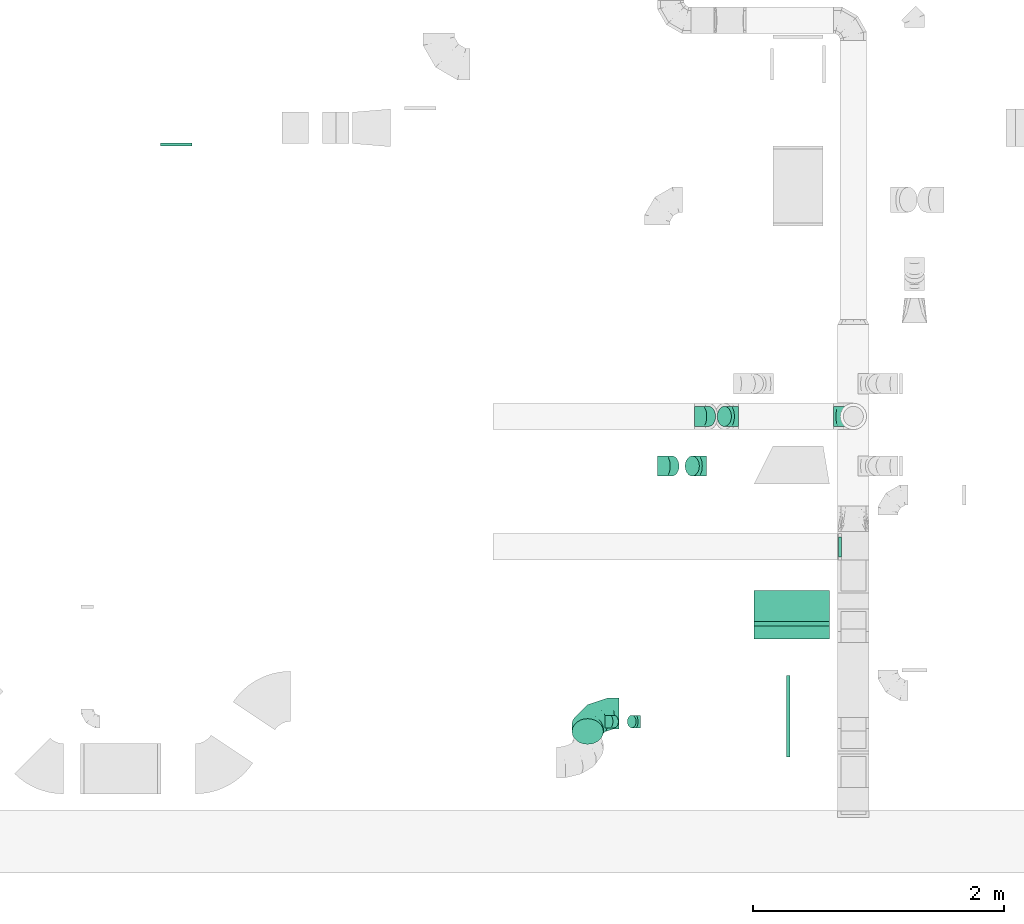
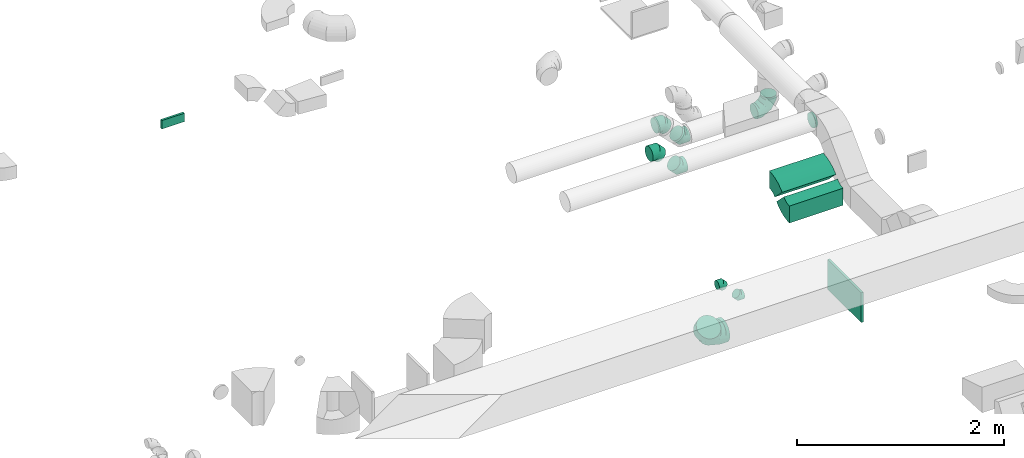
# One storey, part 34 of 62: 13 flow fittings.
"""IFC2X3 building model written with IfcOpenShell, lengths in millimetres."""

import ifcopenshell
import ifcopenshell.guid

model = None  # the IFC model being written
_history = None  # IfcOwnerHistory: only IFC2X3 demands one
_inside = {}  # id of a spatial element -> (the spatial element, [elements in it])
_under = {}  # id of a project, library or spatial element -> (it, [spatial elements below it])
_declared = {}  # id of a project -> (the project, [libraries it declares])
_typed = {}  # id of a type object -> (the type object, [elements of that type])
_made_of = {}  # id of a material, layer set ... -> (it, [elements and type objects made of it])


def new_model(schema):
    """Start an empty IFC model of exactly this schema.

    Asked for "IFC4X3", IfcOpenShell would pick the latest addendum, in which some entities
    have other attributes; the version numbers below select the first issue.
    IFC2X3 requires an IfcOwnerHistory on every rooted entity: one is made here for all.
    """
    global model, _history
    if schema == "IFC4X3":
        model = ifcopenshell.file(schema_version=(4, 3, 0, 0))
    else:
        model = ifcopenshell.file(schema=schema)
    _inside.clear()
    _under.clear()
    _declared.clear()
    _typed.clear()
    _made_of.clear()
    _history = None
    if model.schema == "IFC2X3":
        org = make("IfcOrganization", Name="unknown")
        user = make(
            "IfcPersonAndOrganization",
            ThePerson=make("IfcPerson", FamilyName="unknown"),
            TheOrganization=org,
        )
        app = make(
            "IfcApplication",
            ApplicationDeveloper=org,
            Version="unknown",
            ApplicationFullName="unknown",
            ApplicationIdentifier="unknown",
        )
        _history = make(
            "IfcOwnerHistory",
            OwningUser=user,
            OwningApplication=app,
            ChangeAction="ADDED",
            CreationDate=0,
        )
    return model


def make(cls, **values):
    """One entity of the class cls with the attributes given. An attribute that is None is left unset."""
    return model.create_entity(
        cls, **{name: value for name, value in values.items() if value is not None}
    )


def entity(cls, *values):
    """Any entity or typed value of the class cls, its attributes in the order of the schema. None: left unset."""
    e = model.create_entity(cls)
    for i, value in enumerate(values):
        if value is not None:
            e[i] = value
    return e


def rooted(cls, **values):
    """An entity with a GlobalId (a new one), such as an element, a storey or a relation."""
    return make(cls, GlobalId=ifcopenshell.guid.new(), OwnerHistory=_history, **values)


def si_unit(unit_type, name, prefix=None):
    """IfcSIUnit, for example si_unit("LENGTHUNIT", "METRE", prefix="MILLI")."""
    return make("IfcSIUnit", UnitType=unit_type, Prefix=prefix, Name=name)


def converted_unit(unit_type, name, factor, base, dimensions=None, offset=None):
    """IfcConversionBasedUnit, such as the inch: factor (a typed value) times the base unit."""
    return make(
        "IfcConversionBasedUnit"
        if offset is None
        else "IfcConversionBasedUnitWithOffset",
        ConversionOffset=offset,
        Dimensions=None
        if dimensions is None
        else entity("IfcDimensionalExponents", *dimensions),
        UnitType=unit_type,
        Name=name,
        ConversionFactor=make(
            "IfcMeasureWithUnit", ValueComponent=factor, UnitComponent=base
        ),
    )


def derived_unit(unit_type, elements):
    """IfcDerivedUnit: a product of units, each with its exponent."""
    return make(
        "IfcDerivedUnit",
        Elements=[
            make("IfcDerivedUnitElement", Unit=unit, Exponent=power)
            for unit, power in elements
        ],
        UnitType=unit_type,
    )


def assignment(units):
    """IfcUnitAssignment: the units of a project."""
    return None if units is None else make("IfcUnitAssignment", Units=units)


def point(xyz):
    """IfcCartesianPoint."""
    return None if xyz is None else make("IfcCartesianPoint", Coordinates=xyz)


def direction(xyz):
    """IfcDirection."""
    return None if xyz is None else make("IfcDirection", DirectionRatios=xyz)


def frame(location, z_axis=None, x_axis=None):
    """IfcAxis2Placement3D, a coordinate frame: its origin and axes. An axis left out is left unset."""
    return make(
        "IfcAxis2Placement3D",
        Location=point(location),
        Axis=direction(z_axis),
        RefDirection=direction(x_axis),
    )


def frame_2d(location, x_axis=None):
    """IfcAxis2Placement2D, a coordinate frame in the plane: its origin and x axis."""
    return make(
        "IfcAxis2Placement2D", Location=point(location), RefDirection=direction(x_axis)
    )


def origin():
    """The frame at (0, 0, 0) with its axes left unset."""
    return frame((0.0, 0.0, 0.0))


def origin_2d_with_axis():
    """The frame at (0, 0) in the plane with the x axis (1, 0) written out."""
    return frame_2d((0.0, 0.0), x_axis=(1.0, 0.0))


def place(relative_to, where):
    """IfcLocalPlacement: puts the frame where relative to a parent placement (None: the world)."""
    return make(
        "IfcLocalPlacement", PlacementRelTo=relative_to, RelativePlacement=where
    )


def context(
    kind, dimensions, precision=None, world=None, true_north=None, identifier=None
):
    """IfcGeometricRepresentationContext, for example the 3D "Model" context."""
    return make(
        "IfcGeometricRepresentationContext",
        ContextIdentifier=identifier,
        ContextType=kind,
        CoordinateSpaceDimension=dimensions,
        Precision=precision,
        WorldCoordinateSystem=world,
        TrueNorth=true_north,
    )


def subcontext(parent, identifier, kind, view, scale=None):
    """IfcGeometricRepresentationSubContext, for example "Body" below "Model"."""
    return make(
        "IfcGeometricRepresentationSubContext",
        ContextIdentifier=identifier,
        ContextType=kind,
        ParentContext=parent,
        TargetScale=scale,
        TargetView=view,
    )


def project(units=None, contexts=None):
    """IfcProject with its units and contexts."""
    return rooted(
        "IfcProject",
        Name="project",
        RepresentationContexts=contexts,
        UnitsInContext=assignment(units),
    )


def spatial(cls, under=None, at=None, **own):
    """A site, building, storey or space (cls), placed at a placement, below another one or the project."""
    s = rooted(cls, ObjectPlacement=at, **own)
    if under is not None:
        _under.setdefault(under.id(), (under, []))[1].append(s)
    return s


def polyline(points):
    """IfcPolyline through the points."""
    return make("IfcPolyline", Points=[point(p) for p in points])


def circle_curve(where, radius):
    """IfcCircle in the frame where."""
    return make("IfcCircle", Position=where, Radius=radius)


def parameter(value):
    """IfcParameterValue: where a trimmed curve begins or ends, as a parameter of its basis curve."""
    return model.create_entity("IfcParameterValue", value)


def trimmed(basis, trim1, trim2, sense, master):
    """IfcTrimmedCurve: the piece of a basis curve between two trims."""
    return make(
        "IfcTrimmedCurve",
        BasisCurve=basis,
        Trim1=trim1,
        Trim2=trim2,
        SenseAgreement=sense,
        MasterRepresentation=master,
    )


def segment(curve, same_sense, transition):
    """IfcCompositeCurveSegment."""
    return make(
        "IfcCompositeCurveSegment",
        Transition=transition,
        SameSense=same_sense,
        ParentCurve=curve,
    )


def composite_curve(segments, self_intersect=None):
    """IfcCompositeCurve: segments joined end to end."""
    return make("IfcCompositeCurve", Segments=segments, SelfIntersect=self_intersect)


def profile(cls, at=None, kind="AREA", **sizes):
    """A parametric profile (cls). Its sizes go by their IFC names, for example OverallWidth=200.0."""
    return make(cls, ProfileType=kind, Position=at, **sizes)


def rectangle(**sizes):
    """IfcRectangleProfileDef."""
    return profile("IfcRectangleProfileDef", **sizes)


def outline(outer, holes=None, kind="AREA"):
    """IfcArbitraryClosedProfileDef: a profile drawn as a closed curve; with holes, ...WithVoids."""
    if holes is None:
        return make("IfcArbitraryClosedProfileDef", ProfileType=kind, OuterCurve=outer)
    return make(
        "IfcArbitraryProfileDefWithVoids",
        ProfileType=kind,
        OuterCurve=outer,
        InnerCurves=holes,
    )


def extrude(swept, where, along, depth):
    """IfcExtrudedAreaSolid: the profile swept, set in the frame where, extruded along a direction by depth."""
    return make(
        "IfcExtrudedAreaSolid",
        SweptArea=swept,
        Position=where,
        ExtrudedDirection=direction(along),
        Depth=depth,
    )


def faces_of(points, faces, orient=None, outer=None):
    """IfcFace entities. A face is a list of loops; a loop is a list of indices into points, from 0.

    orient and outer hold one flag for each loop. By default every Orientation is true, the
    first loop of a face is its IfcFaceOuterBound and the others are IfcFaceBound.
    """
    made = []
    for i, loops in enumerate(faces):
        bounds = []
        for j, loop in enumerate(loops):
            is_outer = j == 0 if outer is None else outer[i][j]
            bounds.append(
                make(
                    "IfcFaceOuterBound" if is_outer else "IfcFaceBound",
                    Bound=make("IfcPolyLoop", Polygon=[points[k] for k in loop]),
                    Orientation=True if orient is None else orient[i][j],
                )
            )
        made.append(make("IfcFace", Bounds=bounds))
    return made


def faceted_brep(points, faces, orient=None, outer=None, voids=None):
    """IfcFacetedBrep: a solid bounded by flat faces; with voids (closed shells), ...WithVoids."""
    shared = [point(p) for p in points]
    hull = make("IfcClosedShell", CfsFaces=faces_of(shared, faces, orient, outer))
    if voids is None:
        return make("IfcFacetedBrep", Outer=hull)
    return make(
        "IfcFacetedBrepWithVoids",
        Outer=hull,
        Voids=[
            make(cls, CfsFaces=faces_of(shared, fs, o, b)) for cls, fs, o, b in voids
        ],
    )


def shape(context_of_items, identifier, shape_type, items):
    """IfcShapeRepresentation: the items that make up one representation, for example the "Body"."""
    return make(
        "IfcShapeRepresentation",
        ContextOfItems=context_of_items,
        RepresentationIdentifier=identifier,
        RepresentationType=shape_type,
        Items=items,
    )


def source(mapping_origin, context_of_items, identifier, shape_type, items):
    """IfcRepresentationMap: a shape defined once, which mapped items show again and again."""
    return make(
        "IfcRepresentationMap",
        MappingOrigin=mapping_origin,
        MappedRepresentation=shape(context_of_items, identifier, shape_type, items),
    )


def transform(
    local_origin,
    x_axis=None,
    y_axis=None,
    z_axis=None,
    scale=None,
    scale2=None,
    scale3=None,
    uniform=True,
):
    """IfcCartesianTransformationOperator3D, or its non-uniform kind. x_axis, y_axis, z_axis: its Axis1, 2, 3."""
    if uniform:
        return make(
            "IfcCartesianTransformationOperator3D",
            Axis1=direction(x_axis),
            Axis2=direction(y_axis),
            LocalOrigin=point(local_origin),
            Scale=scale,
            Axis3=direction(z_axis),
        )
    return make(
        "IfcCartesianTransformationOperator3DnonUniform",
        Axis1=direction(x_axis),
        Axis2=direction(y_axis),
        LocalOrigin=point(local_origin),
        Scale=scale,
        Axis3=direction(z_axis),
        Scale2=scale2,
        Scale3=scale3,
    )


def mapped(mapping_source, mapping_target):
    """IfcMappedItem: shows the shape of a source again, moved by a transform."""
    return make(
        "IfcMappedItem", MappingSource=mapping_source, MappingTarget=mapping_target
    )


def material(Name=None, Category=None):
    """IfcMaterial."""
    return make("IfcMaterial", Name=Name, Category=Category)


def made_of(thing, what):
    """Note that an element or type object is made of a material, layer set ...; save() writes the relation."""
    if what is not None:
        _made_of.setdefault(what.id(), (what, []))[1].append(thing)
    return thing


def type_object(cls, material=None, **own):
    """A type object (cls), such as IfcWallType, which elements share."""
    return made_of(rooted(cls, **own), material)


def type_shapes(of_type, sources):
    """Give a type object the sources (RepresentationMaps) that its elements show as mapped items."""
    of_type.RepresentationMaps = sources


def element(
    cls,
    number,
    at=None,
    inside=None,
    cuts=None,
    type_object=None,
    material=None,
    context=None,
    identifier="Body",
    shape_type=None,
    held_by="IfcProductDefinitionShape",
    body=None,
    shapes=None,
    **own,
):
    """One element of the class cls, such as IfcWall. Its Tag is "e" and its number.

    at: its placement. inside: the storey or other place that contains it. cuts: it is an
    opening in that element (IfcRelVoidsElement). A single representation is given by context,
    identifier, shape_type and body (its items); several are given by shapes. held_by: the class
    of the entity that holds the representations. save() writes the other relations.
    """
    e = rooted(cls, Tag="e%d" % number, ObjectPlacement=at, **own)
    if body is not None:
        shapes = [shape(context, identifier, shape_type, body)]
    if shapes is not None:
        e.Representation = make(held_by, Representations=shapes)
    if inside is not None:
        _inside.setdefault(inside.id(), (inside, []))[1].append(e)
    if cuts is not None:
        rooted(
            "IfcRelVoidsElement", RelatingBuildingElement=cuts, RelatedOpeningElement=e
        )
    if type_object is not None:
        _typed.setdefault(type_object.id(), (type_object, []))[1].append(e)
    return made_of(e, material)


def aggregate(whole, parts):
    """IfcRelAggregates: a whole, such as a stair, and the parts it consists of."""
    return rooted("IfcRelAggregates", RelatingObject=whole, RelatedObjects=parts)


def save(model, path):
    """Write the relations noted so far, then the file.

    IfcRelAggregates (storeys below a building ...), IfcRelContainedInSpatialStructure (elements
    in a storey), IfcRelDefinesByType, IfcRelAssociatesMaterial and IfcRelDeclares: one each for
    every whole, place, type object, material and project.
    """
    for whole, parts in _under.values():
        aggregate(whole, parts)
    for where, things in _inside.values():
        rooted(
            "IfcRelContainedInSpatialStructure",
            RelatedElements=things,
            RelatingStructure=where,
        )
    for kind, things in _typed.values():
        rooted("IfcRelDefinesByType", RelatedObjects=things, RelatingType=kind)
    for what, things in _made_of.values():
        rooted("IfcRelAssociatesMaterial", RelatedObjects=things, RelatingMaterial=what)
    for by, libraries in _declared.values():
        rooted("IfcRelDeclares", RelatingContext=by, RelatedDefinitions=libraries)
    model.write(path)


model = new_model("IFC2X3")

# Units and contexts
model_context = context("Model", 3, precision=0.01, world=origin(), true_north=direction((6.12303176911189e-17, 1.0)))
body_context = subcontext(model_context, "Body", "Model", "MODEL_VIEW")
ifc_project = project(units=[si_unit("LENGTHUNIT", "METRE", prefix="MILLI"), si_unit("AREAUNIT", "SQUARE_METRE"), si_unit("VOLUMEUNIT", "CUBIC_METRE"), converted_unit("PLANEANGLEUNIT", "DEGREE", entity("IfcRatioMeasure", 0.0174532925199433), si_unit("PLANEANGLEUNIT", "RADIAN"), dimensions=[0, 0, 0, 0, 0, 0, 0]), si_unit("MASSUNIT", "GRAM", prefix="KILO"), derived_unit("MASSDENSITYUNIT", [(si_unit("MASSUNIT", "GRAM", prefix="KILO"), 1), (si_unit("LENGTHUNIT", "METRE"), -3)]), derived_unit("MOMENTOFINERTIAUNIT", [(si_unit("LENGTHUNIT", "METRE"), 4)]), si_unit("TIMEUNIT", "SECOND"), si_unit("FREQUENCYUNIT", "HERTZ"), si_unit("THERMODYNAMICTEMPERATUREUNIT", "DEGREE_CELSIUS"), derived_unit("THERMALTRANSMITTANCEUNIT", [(si_unit("MASSUNIT", "GRAM", prefix="KILO"), 1), (si_unit("THERMODYNAMICTEMPERATUREUNIT", "KELVIN"), -1), (si_unit("TIMEUNIT", "SECOND"), -3)]), derived_unit("VOLUMETRICFLOWRATEUNIT", [(si_unit("LENGTHUNIT", "METRE"), 3), (si_unit("TIMEUNIT", "SECOND"), -1)]), derived_unit("MASSFLOWRATEUNIT", [(si_unit("MASSUNIT", "GRAM", prefix="KILO"), 1), (si_unit("TIMEUNIT", "SECOND"), -1)]), derived_unit("ROTATIONALFREQUENCYUNIT", [(si_unit("TIMEUNIT", "SECOND"), -1)]), si_unit("ELECTRICCURRENTUNIT", "AMPERE"), si_unit("ELECTRICVOLTAGEUNIT", "VOLT"), si_unit("POWERUNIT", "WATT"), si_unit("FORCEUNIT", "NEWTON", prefix="KILO"), si_unit("ILLUMINANCEUNIT", "LUX"), si_unit("LUMINOUSFLUXUNIT", "LUMEN"), si_unit("LUMINOUSINTENSITYUNIT", "CANDELA"), derived_unit("USERDEFINED", [(si_unit("MASSUNIT", "GRAM", prefix="KILO"), -1), (si_unit("LENGTHUNIT", "METRE"), -2), (si_unit("TIMEUNIT", "SECOND"), 3), (si_unit("LUMINOUSFLUXUNIT", "LUMEN"), 1)]), derived_unit("LINEARVELOCITYUNIT", [(si_unit("LENGTHUNIT", "METRE"), 1), (si_unit("TIMEUNIT", "SECOND"), -1)]), si_unit("PRESSUREUNIT", "PASCAL"), derived_unit("USERDEFINED", [(si_unit("LENGTHUNIT", "METRE"), -2), (si_unit("MASSUNIT", "GRAM", prefix="KILO"), 1), (si_unit("TIMEUNIT", "SECOND"), -2)]), derived_unit("LINEARFORCEUNIT", [(si_unit("MASSUNIT", "GRAM", prefix="KILO"), 1), (si_unit("LENGTHUNIT", "METRE"), 1), (si_unit("TIMEUNIT", "SECOND"), -2), (si_unit("LENGTHUNIT", "METRE"), -1)]), derived_unit("PLANARFORCEUNIT", [(si_unit("MASSUNIT", "GRAM", prefix="KILO"), 1), (si_unit("LENGTHUNIT", "METRE"), 1), (si_unit("TIMEUNIT", "SECOND"), -2), (si_unit("LENGTHUNIT", "METRE"), -2)])], contexts=[model_context])

# Site, building, storey
site_placement = place(None, origin())
site = spatial("IfcSite", under=ifc_project, at=site_placement, CompositionType="ELEMENT")
building_placement = place(site_placement, origin())
building = spatial("IfcBuilding", under=site, at=building_placement, CompositionType="ELEMENT")
storey_placement = place(building_placement, frame((0.0, 0.0, 24000.0)))
storey = spatial("IfcBuildingStorey", under=building, at=storey_placement, CompositionType="ELEMENT", Elevation=24000.0)

# Flow fittings
ifc_material = material()
duct_fitting_type_1 = type_object("IfcDuctFittingType", PredefinedType="NOTDEFINED", material=ifc_material)
shared_shape_1 = source(origin(), body_context, "Body", "SweptSolid", [
    extrude(rectangle(XDim=26.096000000009, YDim=250.0, at=origin_2d_with_axis()), frame((6.95, 0.0, -50.0)), (0.0, 0.0, 1.0), 100.0),
])
type_shapes(duct_fitting_type_1, [shared_shape_1])
flow_fitting_1_placement = place(storey_placement, frame((45368.22, 14481.21, 3550.0), z_axis=(0.0, 0.0, -1.0), x_axis=(0.0, -1.0, 0.0)))
element("IfcFlowFitting", 1, at=flow_fitting_1_placement, inside=storey, type_object=duct_fitting_type_1, material=ifc_material, context=body_context, shape_type="MappedRepresentation", body=[
    mapped(shared_shape_1, transform((0.0, 0.0, 0.0), scale=1.0)),
])
duct_fitting_type_2 = type_object("IfcDuctFittingType", PredefinedType="NOTDEFINED", material=ifc_material)
shared_shape_2 = source(origin(), body_context, "Body", "SweptSolid", [
    extrude(rectangle(XDim=24.9999999999999, YDim=650.0, at=origin_2d_with_axis()), frame((12.5, 0.0, -175.0)), (0.0, 0.0, 1.0), 350.0),
])
type_shapes(duct_fitting_type_2, [shared_shape_2])
flow_fitting_2_placement = place(storey_placement, frame((50225.82, 9925.03, 2600.0)))
element("IfcFlowFitting", 2, at=flow_fitting_2_placement, inside=storey, type_object=duct_fitting_type_2, material=ifc_material, context=body_context, shape_type="MappedRepresentation", body=[
    mapped(shared_shape_2, transform((0.0, 0.0, 0.0), scale=1.0)),
])
duct_fitting_type_3 = type_object("IfcDuctFittingType", PredefinedType="NOTDEFINED", material=ifc_material)
shared_shape_3 = source(origin(), body_context, "Body", "Brep", [
    faceted_brep([(-160.0, 0.0, -80.0), (-160.0, -20.71, -77.27), (-160.0, -40.0, -69.28), (-160.0, -56.57, -56.57), (-160.0, -69.28, -40.0), (-160.0, -77.27, -20.71), (-160.0, -80.0, 0.0), (-160.0, -77.27, 20.71), (-160.0, -69.28, 40.0), (-160.0, -56.57, 56.57), (-160.0, -40.0, 69.28), (-160.0, -20.71, 77.27), (-160.0, 0.0, 80.0), (-160.0, 20.71, 77.27), (-160.0, 40.0, 69.28), (-160.0, 56.57, 56.57), (-160.0, 69.28, 40.0), (-160.0, 77.27, 20.71), (-160.0, 80.0, 0.0), (-160.0, 77.27, -20.71), (-160.0, 69.28, -40.0), (-160.0, 56.57, -56.57), (-160.0, 40.0, -69.28), (-160.0, 20.71, -77.27), (-122.68, 20.71, 77.27), (-127.85, 40.0, 69.28), (-117.13, 0.0, 80.0), (-132.29, 56.57, 56.57), (-137.83, 77.27, 20.71), (-138.56, 80.0, 0.0), (-135.69, 69.28, 40.0), (-135.69, 69.28, -40.0), (-132.29, 56.57, -56.57), (-137.83, 77.27, -20.71), (-122.68, 20.71, -77.27), (-117.13, 0.0, -80.0), (-127.85, 40.0, -69.28), (-111.58, -20.71, -77.27), (-106.41, -40.0, -69.28), (-101.97, -56.57, -56.57), (-98.56, -69.28, -40.0), (-96.42, -77.27, -20.71), (-95.69, -80.0, 0.0), (-96.42, -77.27, 20.71), (-98.56, -69.28, 40.0), (-101.97, -56.57, 56.57), (-106.41, -40.0, 69.28), (-111.58, -20.71, 77.27), (-58.03, 58.03, 77.27), (-72.15, 72.15, 69.28), (-42.87, 42.87, 80.0), (-84.28, 84.28, 56.57), (-93.59, 93.59, 40.0), (-99.44, 99.44, 20.71), (-101.44, 101.44, 0.0), (-99.44, 99.44, -20.71), (-93.59, 93.59, -40.0), (-84.28, 84.28, -56.57), (-58.03, 58.03, -77.27), (-42.87, 42.87, -80.0), (-72.15, 72.15, -69.28), (-27.71, 27.71, -77.27), (-13.59, 13.59, -69.28), (-1.46, 1.46, -56.57), (7.85, -7.85, -40.0), (13.7, -13.7, -20.71), (15.69, -15.69, 0.0), (13.7, -13.7, 20.71), (7.85, -7.85, 40.0), (-1.46, 1.46, 56.57), (-13.59, 13.59, 69.28), (-27.71, 27.71, 77.27), (-20.71, 122.68, 77.27), (-40.0, 127.85, 69.28), (0.0, 117.13, 80.0), (-56.57, 132.29, 56.57), (-69.28, 135.69, 40.0), (-77.27, 137.83, 20.71), (-80.0, 138.56, 0.0), (-77.27, 137.83, -20.71), (-69.28, 135.69, -40.0), (-56.57, 132.29, -56.57), (-20.71, 122.68, -77.27), (0.0, 117.13, -80.0), (-40.0, 127.85, -69.28), (20.71, 111.58, -77.27), (40.0, 106.41, -69.28), (56.57, 101.97, -56.57), (69.28, 98.56, -40.0), (77.27, 96.42, -20.71), (80.0, 95.69, 0.0), (77.27, 96.42, 20.71), (69.28, 98.56, 40.0), (56.57, 101.97, 56.57), (40.0, 106.41, 69.28), (20.71, 111.58, 77.27), (-20.71, 160.0, -77.27), (-40.0, 160.0, -69.28), (-56.57, 160.0, -56.57), (-69.28, 160.0, -40.0), (-77.27, 160.0, -20.71), (-80.0, 160.0, 0.0), (-77.27, 160.0, 20.71), (-69.28, 160.0, 40.0), (-56.57, 160.0, 56.57), (-40.0, 160.0, 69.28), (-20.71, 160.0, 77.27), (0.0, 160.0, 80.0), (20.71, 160.0, 77.27), (40.0, 160.0, 69.28), (56.57, 160.0, 56.57), (69.28, 160.0, 40.0), (77.27, 160.0, 20.71), (80.0, 160.0, 0.0), (77.27, 160.0, -20.71), (69.28, 160.0, -40.0), (56.57, 160.0, -56.57), (40.0, 160.0, -69.28), (20.71, 160.0, -77.27), (0.0, 160.0, -80.0)], [[[0, 1, 2, 3, 4, 5, 6, 7, 8, 9, 10, 11, 12, 13, 14, 15, 16, 17, 18, 19, 20, 21, 22, 23]], [[24, 25, 14, 13]], [[26, 24, 13, 12]], [[14, 25, 27, 15]], [[28, 29, 18, 17]], [[30, 28, 17, 16]], [[15, 27, 30, 16]], [[20, 31, 32, 21]], [[33, 31, 20, 19]], [[18, 29, 33, 19]], [[34, 35, 0, 23]], [[36, 34, 23, 22]], [[32, 36, 22, 21]], [[1, 0, 35, 37]], [[2, 1, 37, 38]], [[3, 2, 38, 39]], [[5, 4, 40, 41]], [[6, 5, 41, 42]], [[39, 40, 4, 3]], [[6, 42, 43, 7]], [[7, 43, 44, 8]], [[8, 44, 45, 9]], [[9, 45, 46, 10]], [[10, 46, 47, 11]], [[26, 12, 11, 47]], [[48, 49, 25, 24]], [[50, 48, 24, 26]], [[27, 25, 49, 51]], [[52, 53, 28, 30]], [[51, 52, 30, 27]], [[29, 28, 53, 54]], [[55, 56, 31, 33]], [[54, 55, 33, 29]], [[32, 31, 56, 57]], [[58, 59, 35, 34]], [[60, 58, 34, 36]], [[57, 60, 36, 32]], [[37, 35, 59, 61]], [[38, 37, 61, 62]], [[39, 38, 62, 63]], [[41, 40, 64, 65]], [[42, 41, 65, 66]], [[63, 64, 40, 39]], [[43, 42, 66, 67]], [[44, 43, 67, 68]], [[68, 69, 45, 44]], [[46, 45, 69, 70]], [[47, 46, 70, 71]], [[26, 47, 71, 50]], [[72, 73, 49, 48]], [[74, 72, 48, 50]], [[51, 49, 73, 75]], [[76, 77, 53, 52]], [[75, 76, 52, 51]], [[54, 53, 77, 78]], [[79, 80, 56, 55]], [[78, 79, 55, 54]], [[57, 56, 80, 81]], [[82, 83, 59, 58]], [[84, 82, 58, 60]], [[81, 84, 60, 57]], [[61, 59, 83, 85]], [[62, 61, 85, 86]], [[63, 62, 86, 87]], [[65, 64, 88, 89]], [[66, 65, 89, 90]], [[87, 88, 64, 63]], [[67, 66, 90, 91]], [[68, 67, 91, 92]], [[92, 93, 69, 68]], [[70, 69, 93, 94]], [[71, 70, 94, 95]], [[50, 71, 95, 74]], [[96, 97, 98, 99, 100, 101, 102, 103, 104, 105, 106, 107, 108, 109, 110, 111, 112, 113, 114, 115, 116, 117, 118, 119]], [[72, 74, 107, 106]], [[73, 72, 106, 105]], [[75, 73, 105, 104]], [[77, 76, 103, 102]], [[78, 77, 102, 101]], [[75, 104, 103, 76]], [[78, 101, 100, 79]], [[79, 100, 99, 80]], [[80, 99, 98, 81]], [[84, 97, 96, 82]], [[82, 96, 119, 83]], [[84, 81, 98, 97]], [[118, 117, 86, 85]], [[119, 118, 85, 83]], [[116, 87, 86, 117]], [[88, 115, 114, 89]], [[89, 114, 113, 90]], [[115, 88, 87, 116]], [[112, 111, 92, 91]], [[113, 112, 91, 90]], [[111, 110, 93, 92]], [[95, 94, 109, 108]], [[74, 95, 108, 107]], [[110, 109, 94, 93]]]),
])
type_shapes(duct_fitting_type_3, [shared_shape_3])
flow_fitting_3_placement = place(storey_placement, frame((50756.62, 12310.04, 3140.0), z_axis=(0.0, -1.0, 0.0), x_axis=(1.0, 0.0, 0.0)))
element("IfcFlowFitting", 3, at=flow_fitting_3_placement, inside=storey, type_object=duct_fitting_type_3, material=ifc_material, context=body_context, shape_type="MappedRepresentation", body=[
    mapped(shared_shape_3, transform((0.0, 0.0, 0.0), scale=1.0)),
])
duct_fitting_type_4 = type_object("IfcDuctFittingType", PredefinedType="NOTDEFINED", material=ifc_material)
shared_shape_4 = source(origin(), body_context, "Body", "Brep", [
    faceted_brep([(-250.0, 0.0, -125.0), (-250.0, -32.35, -120.74), (-250.0, -62.5, -108.25), (-250.0, -88.39, -88.39), (-250.0, -108.25, -62.5), (-250.0, -120.74, -32.35), (-250.0, -125.0, 0.0), (-250.0, -120.74, 32.35), (-250.0, -108.25, 62.5), (-250.0, -88.39, 88.39), (-250.0, -62.5, 108.25), (-250.0, -32.35, 120.74), (-250.0, 0.0, 125.0), (-250.0, 32.35, 120.74), (-250.0, 62.5, 108.25), (-250.0, 88.39, 88.39), (-250.0, 108.25, 62.5), (-250.0, 120.74, 32.35), (-250.0, 125.0, 0.0), (-250.0, 120.74, -32.35), (-250.0, 108.25, -62.5), (-250.0, 88.39, -88.39), (-250.0, 62.5, -108.25), (-250.0, 32.35, -120.74), (-191.68, 32.35, 120.74), (-199.76, 62.5, 108.25), (-183.01, 0.0, 125.0), (-206.7, 88.39, 88.39), (-215.37, 120.74, 32.35), (-216.51, 125.0, 0.0), (-212.02, 108.25, 62.5), (-212.02, 108.25, -62.5), (-206.7, 88.39, -88.39), (-215.37, 120.74, -32.35), (-191.68, 32.35, -120.74), (-183.01, 0.0, -125.0), (-199.76, 62.5, -108.25), (-174.34, -32.35, -120.74), (-166.27, -62.5, -108.25), (-159.33, -88.39, -88.39), (-154.01, -108.25, -62.5), (-150.66, -120.74, -32.35), (-149.52, -125.0, 0.0), (-150.66, -120.74, 32.35), (-154.01, -108.25, 62.5), (-159.33, -88.39, 88.39), (-166.27, -62.5, 108.25), (-174.34, -32.35, 120.74), (-90.67, 90.67, 120.74), (-112.74, 112.74, 108.25), (-66.99, 66.99, 125.0), (-131.69, 131.69, 88.39), (-146.23, 146.23, 62.5), (-155.38, 155.38, 32.35), (-158.49, 158.49, 0.0), (-155.38, 155.38, -32.35), (-146.23, 146.23, -62.5), (-131.69, 131.69, -88.39), (-90.67, 90.67, -120.74), (-66.99, 66.99, -125.0), (-112.74, 112.74, -108.25), (-43.3, 43.3, -120.74), (-21.23, 21.23, -108.25), (-2.28, 2.28, -88.39), (12.26, -12.26, -62.5), (21.4, -21.4, -32.35), (24.52, -24.52, 0.0), (21.4, -21.4, 32.35), (12.26, -12.26, 62.5), (-2.28, 2.28, 88.39), (-21.23, 21.23, 108.25), (-43.3, 43.3, 120.74), (-32.35, 191.68, 120.74), (-62.5, 199.76, 108.25), (0.0, 183.01, 125.0), (-88.39, 206.7, 88.39), (-108.25, 212.02, 62.5), (-120.74, 215.37, 32.35), (-125.0, 216.51, 0.0), (-120.74, 215.37, -32.35), (-108.25, 212.02, -62.5), (-88.39, 206.7, -88.39), (-32.35, 191.68, -120.74), (0.0, 183.01, -125.0), (-62.5, 199.76, -108.25), (32.35, 174.34, -120.74), (62.5, 166.27, -108.25), (88.39, 159.33, -88.39), (108.25, 154.01, -62.5), (120.74, 150.66, -32.35), (125.0, 149.52, 0.0), (120.74, 150.66, 32.35), (108.25, 154.01, 62.5), (88.39, 159.33, 88.39), (62.5, 166.27, 108.25), (32.35, 174.34, 120.74), (-32.35, 250.0, -120.74), (-62.5, 250.0, -108.25), (-88.39, 250.0, -88.39), (-108.25, 250.0, -62.5), (-120.74, 250.0, -32.35), (-125.0, 250.0, 0.0), (-120.74, 250.0, 32.35), (-108.25, 250.0, 62.5), (-88.39, 250.0, 88.39), (-62.5, 250.0, 108.25), (-32.35, 250.0, 120.74), (0.0, 250.0, 125.0), (32.35, 250.0, 120.74), (62.5, 250.0, 108.25), (88.39, 250.0, 88.39), (108.25, 250.0, 62.5), (120.74, 250.0, 32.35), (125.0, 250.0, 0.0), (120.74, 250.0, -32.35), (108.25, 250.0, -62.5), (88.39, 250.0, -88.39), (62.5, 250.0, -108.25), (32.35, 250.0, -120.74), (0.0, 250.0, -125.0)], [[[0, 1, 2, 3, 4, 5, 6, 7, 8, 9, 10, 11, 12, 13, 14, 15, 16, 17, 18, 19, 20, 21, 22, 23]], [[24, 25, 14, 13]], [[26, 24, 13, 12]], [[14, 25, 27, 15]], [[28, 29, 18, 17]], [[30, 28, 17, 16]], [[15, 27, 30, 16]], [[20, 31, 32, 21]], [[33, 31, 20, 19]], [[18, 29, 33, 19]], [[34, 35, 0, 23]], [[36, 34, 23, 22]], [[21, 32, 36, 22]], [[1, 0, 35, 37]], [[2, 1, 37, 38]], [[38, 39, 3, 2]], [[5, 4, 40, 41]], [[6, 5, 41, 42]], [[39, 40, 4, 3]], [[6, 42, 43, 7]], [[7, 43, 44, 8]], [[8, 44, 45, 9]], [[9, 45, 46, 10]], [[10, 46, 47, 11]], [[26, 12, 11, 47]], [[48, 49, 25, 24]], [[50, 48, 24, 26]], [[27, 25, 49, 51]], [[52, 53, 28, 30]], [[51, 52, 30, 27]], [[29, 28, 53, 54]], [[55, 56, 31, 33]], [[54, 55, 33, 29]], [[32, 31, 56, 57]], [[58, 59, 35, 34]], [[60, 58, 34, 36]], [[57, 60, 36, 32]], [[37, 35, 59, 61]], [[38, 37, 61, 62]], [[39, 38, 62, 63]], [[41, 40, 64, 65]], [[42, 41, 65, 66]], [[63, 64, 40, 39]], [[43, 42, 66, 67]], [[44, 43, 67, 68]], [[68, 69, 45, 44]], [[46, 45, 69, 70]], [[47, 46, 70, 71]], [[26, 47, 71, 50]], [[72, 73, 49, 48]], [[74, 72, 48, 50]], [[51, 49, 73, 75]], [[76, 77, 53, 52]], [[75, 76, 52, 51]], [[54, 53, 77, 78]], [[79, 80, 56, 55]], [[78, 79, 55, 54]], [[57, 56, 80, 81]], [[82, 83, 59, 58]], [[84, 82, 58, 60]], [[81, 84, 60, 57]], [[61, 59, 83, 85]], [[62, 61, 85, 86]], [[63, 62, 86, 87]], [[65, 64, 88, 89]], [[66, 65, 89, 90]], [[87, 88, 64, 63]], [[67, 66, 90, 91]], [[68, 67, 91, 92]], [[92, 93, 69, 68]], [[70, 69, 93, 94]], [[71, 70, 94, 95]], [[50, 71, 95, 74]], [[96, 97, 98, 99, 100, 101, 102, 103, 104, 105, 106, 107, 108, 109, 110, 111, 112, 113, 114, 115, 116, 117, 118, 119]], [[72, 74, 107, 106]], [[73, 72, 106, 105]], [[75, 73, 105, 104]], [[77, 76, 103, 102]], [[78, 77, 102, 101]], [[75, 104, 103, 76]], [[78, 101, 100, 79]], [[79, 100, 99, 80]], [[80, 99, 98, 81]], [[84, 97, 96, 82]], [[82, 96, 119, 83]], [[84, 81, 98, 97]], [[83, 119, 118, 85]], [[85, 118, 117, 86]], [[116, 87, 86, 117]], [[88, 115, 114, 89]], [[89, 114, 113, 90]], [[115, 88, 87, 116]], [[91, 90, 113, 112]], [[92, 91, 112, 111]], [[111, 110, 93, 92]], [[95, 94, 109, 108]], [[74, 95, 108, 107]], [[110, 109, 94, 93]]]),
])
type_shapes(duct_fitting_type_4, [shared_shape_4])
flow_fitting_4_placement = place(storey_placement, frame((48642.33, 9946.23, 2600.0), z_axis=(0.0, 0.81819770358622, 0.574936968585458), x_axis=(-1.0, 0.0, 0.0)))
element("IfcFlowFitting", 4, at=flow_fitting_4_placement, inside=storey, type_object=duct_fitting_type_4, material=ifc_material, context=body_context, shape_type="MappedRepresentation", body=[
    mapped(shared_shape_4, transform((0.0, 0.0, 0.0), scale=1.0)),
])
duct_fitting_type_5 = type_object("IfcDuctFittingType", PredefinedType="NOTDEFINED", material=ifc_material)
shared_shape_5 = source(origin(), body_context, "Body", "Brep", [
    faceted_brep([(-66.27, 0.0, -80.0), (-66.27, -20.71, -77.27), (-66.27, -40.0, -69.28), (-66.27, -56.57, -56.57), (-66.27, -69.28, -40.0), (-66.27, -77.27, -20.71), (-66.27, -80.0, 0.0), (-66.27, -77.27, 20.71), (-66.27, -69.28, 40.0), (-66.27, -56.57, 56.57), (-66.27, -40.0, 69.28), (-66.27, -20.71, 77.27), (-66.27, 0.0, 80.0), (-66.27, 20.71, 77.27), (-66.27, 40.0, 69.28), (-66.27, 56.57, 56.57), (-66.27, 69.28, 40.0), (-66.27, 77.27, 20.71), (-66.27, 80.0, 0.0), (-66.27, 77.27, -20.71), (-66.27, 69.28, -40.0), (-66.27, 56.57, -56.57), (-66.27, 40.0, -69.28), (-66.27, 20.71, -77.27), (-8.58, 20.71, 77.27), (-16.57, 40.0, 69.28), (0.0, 0.0, 80.0), (-23.43, 56.57, 56.57), (-28.7, 69.28, 40.0), (-32.01, 77.27, 20.71), (-33.14, 80.0, 0.0), (-32.01, 77.27, -20.71), (-28.7, 69.28, -40.0), (-23.43, 56.57, -56.57), (-8.58, 20.71, -77.27), (0.0, 0.0, -80.0), (-16.57, 40.0, -69.28), (8.58, -20.71, -77.27), (16.57, -40.0, -69.28), (23.43, -56.57, -56.57), (28.7, -69.28, -40.0), (32.01, -77.27, -20.71), (33.14, -80.0, 0.0), (32.01, -77.27, 20.71), (28.7, -69.28, 40.0), (23.43, -56.57, 56.57), (16.57, -40.0, 69.28), (8.58, -20.71, 77.27), (46.86, 46.86, 80.0), (32.22, 61.5, 77.27), (18.58, 75.15, 69.28), (6.86, 86.86, 56.57), (-2.13, 95.85, 40.0), (-7.78, 101.5, 20.71), (-9.71, 103.43, 0.0), (-7.78, 101.5, -20.71), (-2.13, 95.85, -40.0), (6.86, 86.86, -56.57), (18.58, 75.15, -69.28), (32.22, 61.5, -77.27), (46.86, 46.86, -80.0), (61.5, 32.22, -77.27), (75.15, 18.58, -69.28), (86.86, 6.86, -56.57), (95.85, -2.13, -40.0), (101.5, -7.78, -20.71), (103.43, -9.71, 0.0), (101.5, -7.78, 20.71), (95.85, -2.13, 40.0), (86.86, 6.86, 56.57), (75.15, 18.58, 69.28), (61.5, 32.22, 77.27)], [[[0, 1, 2, 3, 4, 5, 6, 7, 8, 9, 10, 11, 12, 13, 14, 15, 16, 17, 18, 19, 20, 21, 22, 23]], [[24, 25, 14, 13]], [[26, 24, 13, 12]], [[14, 25, 27, 15]], [[28, 29, 17, 16]], [[28, 16, 15, 27]], [[30, 18, 17, 29]], [[31, 32, 20, 19]], [[30, 31, 19, 18]], [[32, 33, 21, 20]], [[34, 35, 0, 23]], [[36, 34, 23, 22]], [[33, 36, 22, 21]], [[1, 0, 35, 37]], [[2, 1, 37, 38]], [[38, 39, 3, 2]], [[5, 4, 40, 41]], [[6, 5, 41, 42]], [[39, 40, 4, 3]], [[6, 42, 43, 7]], [[7, 43, 44, 8]], [[8, 44, 45, 9]], [[9, 45, 46, 10]], [[10, 46, 47, 11]], [[26, 12, 11, 47]], [[24, 26, 48, 49]], [[25, 24, 49, 50]], [[27, 25, 50, 51]], [[29, 28, 52, 53]], [[30, 29, 53, 54]], [[51, 52, 28, 27]], [[30, 54, 55, 31]], [[31, 55, 56, 32]], [[57, 33, 32, 56]], [[36, 58, 59, 34]], [[34, 59, 60, 35]], [[58, 36, 33, 57]], [[35, 60, 61, 37]], [[37, 61, 62, 38]], [[63, 39, 38, 62]], [[40, 64, 65, 41]], [[41, 65, 66, 42]], [[64, 40, 39, 63]], [[43, 42, 66, 67]], [[44, 43, 67, 68]], [[68, 69, 45, 44]], [[47, 46, 70, 71]], [[26, 47, 71, 48]], [[69, 70, 46, 45]], [[59, 58, 57, 56, 55, 54, 53, 52, 51, 50, 49, 48, 71, 70, 69, 68, 67, 66, 65, 64, 63, 62, 61, 60]]]),
])
type_shapes(duct_fitting_type_5, [shared_shape_5])
for number, where, z_axis, x_axis in (
    (5, (49776.62, 12310.04, 3140.0), (0.0, 1.0, 0.0), (-1.0, 0.0, 0.0)),
    (6, (49556.62, 12310.04, 3360.0), (0.0, -1.0, 0.0), (-0.707106781186505, 0.0, 0.70710678118659)),
    (7, (49521.09, 11915.19, 3114.71), (0.0, 1.0, 0.0), (-1.0, 0.0, 0.0)),
    (8, (49265.79, 11915.19, 3370.0), (0.0, -1.0, 0.0), (-0.707106781186503, 0.0, 0.707106781186592)),
):
    element("IfcFlowFitting", number, at=place(storey_placement, frame(where, z_axis=z_axis, x_axis=x_axis)), inside=storey, type_object=duct_fitting_type_5, material=ifc_material, context=body_context, shape_type="MappedRepresentation", body=[
        mapped(shared_shape_5, transform((0.0, 0.0, 0.0), scale=1.0)),
    ])
duct_fitting_type_6 = type_object("IfcDuctFittingType", PredefinedType="NOTDEFINED", material=ifc_material)
shared_shape_6 = source(origin(), body_context, "Body", "Brep", [
    faceted_brep([(-41.42, 0.0, -50.0), (-41.42, -12.94, -48.3), (-41.42, -25.0, -43.3), (-41.42, -35.36, -35.36), (-41.42, -43.3, -25.0), (-41.42, -48.3, -12.94), (-41.42, -50.0, 0.0), (-41.42, -48.3, 12.94), (-41.42, -43.3, 25.0), (-41.42, -35.36, 35.36), (-41.42, -25.0, 43.3), (-41.42, -12.94, 48.3), (-41.42, 0.0, 50.0), (-41.42, 12.94, 48.3), (-41.42, 25.0, 43.3), (-41.42, 35.36, 35.36), (-41.42, 43.3, 25.0), (-41.42, 48.3, 12.94), (-41.42, 50.0, 0.0), (-41.42, 48.3, -12.94), (-41.42, 43.3, -25.0), (-41.42, 35.36, -35.36), (-41.42, 25.0, -43.3), (-41.42, 12.94, -48.3), (-5.36, 12.94, 48.3), (-10.36, 25.0, 43.3), (0.0, 0.0, 50.0), (-14.64, 35.36, 35.36), (-20.0, 48.3, 12.94), (-20.71, 50.0, 0.0), (-17.94, 43.3, 25.0), (-17.94, 43.3, -25.0), (-14.64, 35.36, -35.36), (-20.0, 48.3, -12.94), (-5.36, 12.94, -48.3), (0.0, 0.0, -50.0), (-10.36, 25.0, -43.3), (5.36, -12.94, -48.3), (10.36, -25.0, -43.3), (14.64, -35.36, -35.36), (17.94, -43.3, -25.0), (20.0, -48.3, -12.94), (20.71, -50.0, 0.0), (20.0, -48.3, 12.94), (17.94, -43.3, 25.0), (14.64, -35.36, 35.36), (10.36, -25.0, 43.3), (5.36, -12.94, 48.3), (29.29, 29.29, 50.0), (20.14, 38.44, 48.3), (11.61, 46.97, 43.3), (4.29, 54.29, 35.36), (-1.33, 59.91, 25.0), (-4.86, 63.44, 12.94), (-6.07, 64.64, 0.0), (-4.86, 63.44, -12.94), (-1.33, 59.91, -25.0), (4.29, 54.29, -35.36), (11.61, 46.97, -43.3), (20.14, 38.44, -48.3), (29.29, 29.29, -50.0), (38.44, 20.14, -48.3), (46.97, 11.61, -43.3), (54.29, 4.29, -35.36), (59.91, -1.33, -25.0), (63.44, -4.86, -12.94), (64.64, -6.07, 0.0), (63.44, -4.86, 12.94), (59.91, -1.33, 25.0), (54.29, 4.29, 35.36), (46.97, 11.61, 43.3), (38.44, 20.14, 48.3)], [[[0, 1, 2, 3, 4, 5, 6, 7, 8, 9, 10, 11, 12, 13, 14, 15, 16, 17, 18, 19, 20, 21, 22, 23]], [[24, 25, 14, 13]], [[26, 24, 13, 12]], [[14, 25, 27, 15]], [[28, 29, 18, 17]], [[30, 28, 17, 16]], [[16, 15, 27, 30]], [[20, 31, 32, 21]], [[33, 31, 20, 19]], [[18, 29, 33, 19]], [[34, 35, 0, 23]], [[36, 34, 23, 22]], [[32, 36, 22, 21]], [[1, 0, 35, 37]], [[2, 1, 37, 38]], [[38, 39, 3, 2]], [[5, 4, 40, 41]], [[6, 5, 41, 42]], [[39, 40, 4, 3]], [[6, 42, 43, 7]], [[7, 43, 44, 8]], [[8, 44, 45, 9]], [[9, 45, 46, 10]], [[10, 46, 47, 11]], [[26, 12, 11, 47]], [[24, 26, 48, 49]], [[25, 24, 49, 50]], [[27, 25, 50, 51]], [[28, 30, 52, 53]], [[29, 28, 53, 54]], [[27, 51, 52, 30]], [[29, 54, 55, 33]], [[33, 55, 56, 31]], [[31, 56, 57, 32]], [[36, 58, 59, 34]], [[34, 59, 60, 35]], [[36, 32, 57, 58]], [[61, 62, 38, 37]], [[60, 61, 37, 35]], [[63, 39, 38, 62]], [[40, 64, 65, 41]], [[41, 65, 66, 42]], [[64, 40, 39, 63]], [[43, 42, 66, 67]], [[44, 43, 67, 68]], [[68, 69, 45, 44]], [[47, 46, 70, 71]], [[26, 47, 71, 48]], [[69, 70, 46, 45]], [[59, 58, 57, 56, 55, 54, 53, 52, 51, 50, 49, 48, 71, 70, 69, 68, 67, 66, 65, 64, 63, 62, 61, 60]]]),
])
type_shapes(duct_fitting_type_6, [shared_shape_6])
for number, where, z_axis, x_axis in (
    (9, (48822.09, 9881.53, 3200.0), (0.0, 1.0, 0.0), (1.0, 0.0, 0.0)),
    (10, (49022.09, 9881.53, 3000.0), (0.0, -1.0, 0.0), (0.707106781186309, 0.0, -0.707106781186786)),
):
    element("IfcFlowFitting", number, at=place(storey_placement, frame(where, z_axis=z_axis, x_axis=x_axis)), inside=storey, type_object=duct_fitting_type_6, material=ifc_material, context=body_context, shape_type="MappedRepresentation", body=[
        mapped(shared_shape_6, transform((0.0, 0.0, 0.0), scale=1.0)),
    ])
duct_fitting_type_7 = type_object("IfcDuctFittingType", PredefinedType="NOTDEFINED", material=ifc_material)
shared_shape_7 = source(origin(), body_context, "Body", "Brep", [
    faceted_brep([(20.0, 20.71, -77.27), (20.0, 40.0, -69.28), (20.0, 56.57, -56.57), (20.0, 69.28, -40.0), (20.0, 77.27, -20.71), (20.0, 80.0, 0.0), (20.0, 77.27, 20.71), (20.0, 69.28, 40.0), (20.0, 56.57, 56.57), (20.0, 40.0, 69.28), (20.0, 20.71, 77.27), (20.0, 0.0, 80.0), (20.0, -20.71, 77.27), (20.0, -40.0, 69.28), (20.0, -56.57, 56.57), (20.0, -69.28, 40.0), (20.0, -77.27, 20.71), (20.0, -80.0, 0.0), (20.0, -77.27, -20.71), (20.0, -69.28, -40.0), (20.0, -56.57, -56.57), (20.0, -40.0, -69.28), (20.0, -20.71, -77.27), (20.0, 0.0, -80.0), (0.0, 0.0, 80.0), (0.0, 20.71, 77.27), (-6.1, 20.71, 77.27), (-6.1, 0.0, 80.0), (0.0, 40.0, 69.28), (-6.1, 40.0, 69.28), (0.0, 56.57, 56.57), (-6.1, 56.57, 56.57), (0.0, 69.28, 40.0), (0.0, 77.27, 20.71), (-6.1, 77.27, 20.71), (-6.1, 69.28, 40.0), (0.0, 80.0, 0.0), (-6.1, 80.0, 0.0), (0.0, 77.27, -20.71), (-6.1, 77.27, -20.71), (0.0, 69.28, -40.0), (-6.1, 69.28, -40.0), (0.0, 56.57, -56.57), (-6.1, 56.57, -56.57), (0.0, 40.0, -69.28), (0.0, 20.71, -77.27), (-6.1, 20.71, -77.27), (-6.1, 40.0, -69.28), (0.0, 0.0, -80.0), (-6.1, 0.0, -80.0), (0.0, -20.71, -77.27), (-6.1, -20.71, -77.27), (0.0, -40.0, -69.28), (-6.1, -40.0, -69.28), (0.0, -56.57, -56.57), (-6.1, -56.57, -56.57), (0.0, -69.28, -40.0), (0.0, -77.27, -20.71), (-6.1, -77.27, -20.71), (-6.1, -69.28, -40.0), (0.0, -80.0, 0.0), (-6.1, -80.0, 0.0), (0.0, -77.27, 20.71), (-6.1, -77.27, 20.71), (0.0, -69.28, 40.0), (-6.1, -69.28, 40.0), (0.0, -56.57, 56.57), (-6.1, -56.57, 56.57), (0.0, -40.0, 69.28), (0.0, -20.71, 77.27), (-6.1, -20.71, 77.27), (-6.1, -40.0, 69.28)], [[[0, 1, 2, 3, 4, 5, 6, 7, 8, 9, 10, 11, 12, 13, 14, 15, 16, 17, 18, 19, 20, 21, 22, 23]], [[24, 11, 10, 25, 26, 27]], [[25, 10, 9, 28, 29, 26]], [[28, 9, 8, 30, 31, 29]], [[32, 7, 6, 33, 34, 35]], [[33, 6, 5, 36, 37, 34]], [[30, 8, 7, 32, 35, 31]], [[36, 5, 4, 38, 39, 37]], [[38, 4, 3, 40, 41, 39]], [[40, 3, 2, 42, 43, 41]], [[44, 1, 0, 45, 46, 47]], [[45, 0, 23, 48, 49, 46]], [[42, 2, 1, 44, 47, 43]], [[48, 23, 22, 50, 51, 49]], [[50, 22, 21, 52, 53, 51]], [[52, 21, 20, 54, 55, 53]], [[56, 19, 18, 57, 58, 59]], [[57, 18, 17, 60, 61, 58]], [[54, 20, 19, 56, 59, 55]], [[60, 17, 16, 62, 63, 61]], [[62, 16, 15, 64, 65, 63]], [[64, 15, 14, 66, 67, 65]], [[68, 13, 12, 69, 70, 71]], [[69, 12, 11, 24, 27, 70]], [[66, 14, 13, 68, 71, 67]], [[49, 51, 53, 55, 59, 58, 61, 63, 65, 67, 71, 70, 27, 26, 29, 31, 35, 34, 37, 39, 41, 43, 47, 46]]]),
])
type_shapes(duct_fitting_type_7, [shared_shape_7])
flow_fitting_5_placement = place(storey_placement, frame((50656.62, 11272.02, 3650.0), z_axis=(0.0, 0.0, -1.0), x_axis=(-1.0, 0.0, 0.0)))
element("IfcFlowFitting", 11, at=flow_fitting_5_placement, inside=storey, type_object=duct_fitting_type_7, material=ifc_material, context=body_context, shape_type="MappedRepresentation", body=[
    mapped(shared_shape_7, transform((0.0, 0.0, 0.0), scale=1.0)),
])
duct_fitting_type_8 = type_object("IfcDuctFittingType", PredefinedType="NOTDEFINED", material=ifc_material)
shared_shape_8 = source(origin(), body_context, "Body", "SweptSolid", [
    extrude(outline(composite_curve([segment(polyline([(-136.61, -88.39), (63.39, -88.39)]), True, "CONTINUOUS"), segment(trimmed(circle_curve(frame_2d((213.39, -88.39), x_axis=(-0.707106781186546, 0.707106781186546)), 150.0), [parameter(0.0)], [parameter(45.0)], True, "PARAMETER"), False, "CONTINUOUS"), segment(polyline([(107.32, 17.68), (-34.1, 159.1)]), True, "CONTINUOUS"), segment(trimmed(circle_curve(frame_2d((213.39, -88.39), x_axis=(-0.707106781186546, 0.707106781186546)), 350.0), [parameter(0.0)], [parameter(45.0)], True, "PARAMETER"), True, "CONTINUOUS")], self_intersect=False)), frame((-15.17, 36.61, -300.0), z_axis=(0.0, 0.0, 1.0), x_axis=(-0.707106781186547, 0.707106781186548, 0.0)), (0.0, 0.0, 1.0), 600.0),
])
type_shapes(duct_fitting_type_8, [shared_shape_8])
for number, where, z_axis, x_axis in (
    (12, (50266.44, 10640.64, 3220.0), (-1.0, 0.0, 0.0), (0.0, -0.707106781186488, -0.707106781186607)),
    (13, (50266.44, 10820.64, 3400.0), (-1.0, 0.0, 0.0), (0.0, 0.707106781186488, 0.707106781186607)),
):
    element("IfcFlowFitting", number, at=place(storey_placement, frame(where, z_axis=z_axis, x_axis=x_axis)), inside=storey, type_object=duct_fitting_type_8, material=ifc_material, context=body_context, shape_type="MappedRepresentation", body=[
        mapped(shared_shape_8, transform((0.0, 0.0, 0.0), scale=1.0)),
    ])

save(model, "model.ifc")
